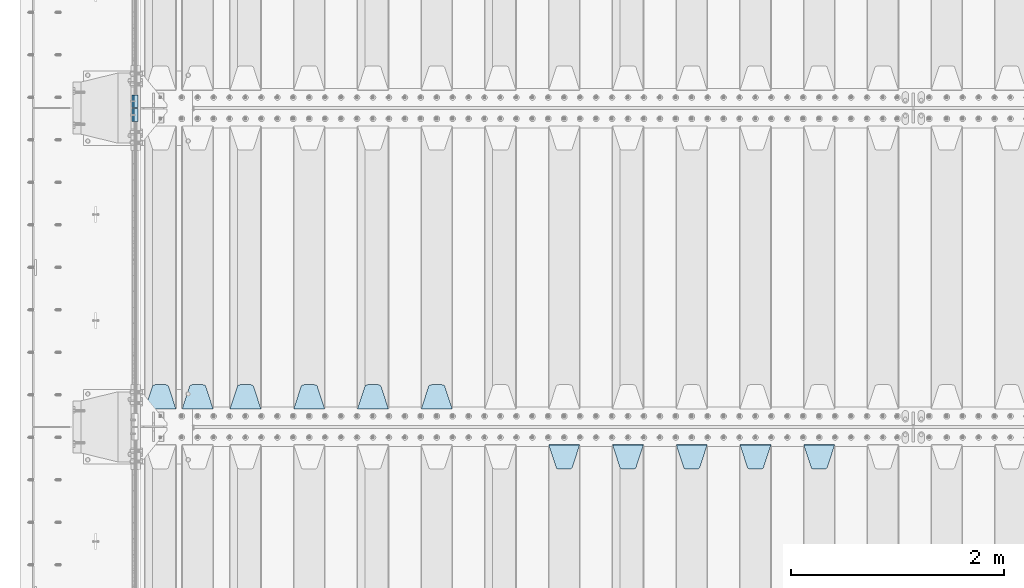
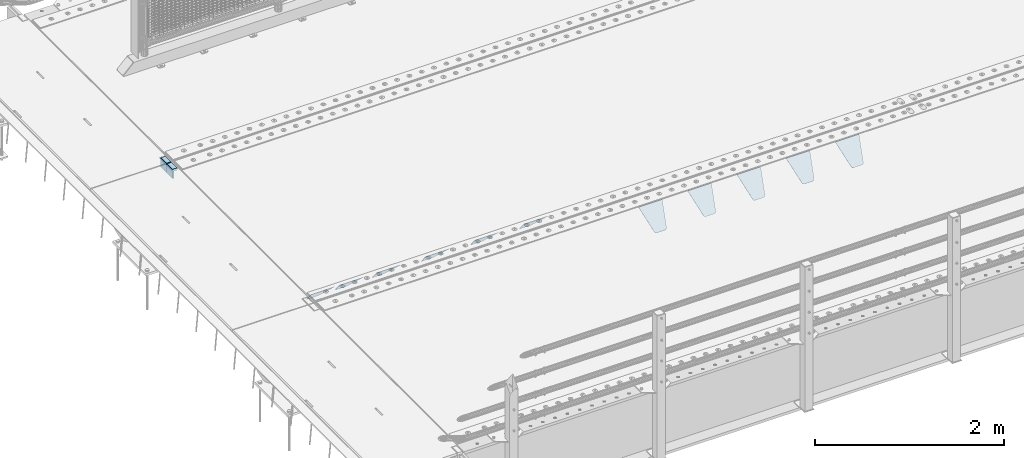
# One storey, part 217 of 270: 15 plates.
"""IFC2X3 building model written with IfcOpenShell, lengths in millimetres."""

from ifc_helpers import new_model, si_unit, frame, origin_with_axes, place, context, subcontext, project, spatial, faceted_brep, material, type_object, element, save


model = new_model("IFC2X3")

# Units and contexts
model_context = context("Model", 3, precision=1e-05, world=origin_with_axes())
body_context = subcontext(model_context, "Body", "Model", "MODEL_VIEW")
ifc_project = project(units=[si_unit("LENGTHUNIT", "METRE", prefix="MILLI"), si_unit("AREAUNIT", "SQUARE_METRE"), si_unit("VOLUMEUNIT", "CUBIC_METRE"), si_unit("MASSUNIT", "GRAM", prefix="KILO"), si_unit("TIMEUNIT", "SECOND"), si_unit("PLANEANGLEUNIT", "RADIAN"), si_unit("SOLIDANGLEUNIT", "STERADIAN"), si_unit("THERMODYNAMICTEMPERATUREUNIT", "DEGREE_CELSIUS"), si_unit("LUMINOUSINTENSITYUNIT", "LUMEN")], contexts=[model_context])

# Site, building, storey
site_placement = place(None, origin_with_axes())
site = spatial("IfcSite", under=ifc_project, at=site_placement, CompositionType="ELEMENT")
building_placement = place(site_placement, origin_with_axes())
building = spatial("IfcBuilding", under=site, at=building_placement, Name="Standard", CompositionType="ELEMENT")
storey_placement = place(building_placement, origin_with_axes())
storey = spatial("IfcBuildingStorey", under=building, at=storey_placement, Name="Undefined", CompositionType="ELEMENT", Elevation=0.0)

# Plates
ifc_material_1 = material()
plate_type_1 = type_object("IfcPlateType", PredefinedType="NOTDEFINED")
for number, where, z_axis, x_axis in (
    (1, (-9.99999993997335, -18064.9999995664, -16.000386849525), (-1.0, 0.0, 0.0), (0.0, -4.95099997756316e-06, 0.999999999987744)),
    (2, (-10.0000000600267, -17934.9999995681, -15.9997432191214), (-1.0, 0.0, 0.0), (0.0, -4.95099997756316e-06, 0.999999999987744)),
):
    element("IfcPlate", number, at=place(storey_placement, frame(where, z_axis=z_axis, x_axis=x_axis)), inside=storey, type_object=plate_type_1, material=ifc_material_1, context=body_context, shape_type="Brep", body=[
        faceted_brep([(1.77635683940025e-15, -60.0000000000073, 0.0), (-0.000933120085688799, -60.0000000000036, 60.0), (-0.000933120085688799, 59.9999999999964, 60.0), (-1.77635683940025e-15, 59.9999999999964, 0.0), (24.9991450303709, -60.0, 60.0), (24.9991450303709, 59.9999999999964, 60.0), (26.544215218168, -60.0000000000036, 59.7552873850884), (26.544215218168, 60.0, 59.7552873850884), (27.9380461396139, -60.0000000000036, 59.0451032459123), (27.9380461396139, 60.0, 59.0451032459123), (29.0442025908961, -60.0000000000036, 57.9389639895784), (29.0442025908961, 60.0, 57.9389639895784), (29.7544083969366, -60.0, 56.5451441080361), (29.7544083969366, 60.0000000000036, 56.5451441080361), (29.9991450297669, -60.0000000000036, 55.0000777244568), (29.9991450297669, 60.0, 55.0000777244568), (29.999922274335, -60.0, 5.00007772445705), (29.999922274335, 60.0, 5.00007772445704), (29.7552240705896, -60.0000000000036, 3.45497416452589), (29.7552240705896, 60.0, 3.45497416452589), (29.0450346578116, -60.0, 2.06111146690959), (29.0450346578116, 59.9999999999964, 2.0611114669096), (27.9388736885072, -60.0, 0.954933302319514), (27.9388736885072, 59.9999999999964, 0.954933302319516), (26.5450220308766, -60.0000000000036, 0.244722222183089), (26.5450220308766, 60.0, 0.244722222183091), (24.9999222749392, -60.0, 2.66453525910038e-13), (24.9999222749392, 60.0, 2.66453525910038e-13)], [[[0, 1, 2, 3]], [[1, 4, 5, 2]], [[4, 6, 7, 5]], [[6, 8, 9, 7]], [[8, 10, 11, 9]], [[10, 12, 13, 11]], [[12, 14, 15, 13]], [[14, 16, 17, 15]], [[16, 18, 19, 17]], [[18, 20, 21, 19]], [[20, 22, 23, 21]], [[22, 24, 25, 23]], [[24, 26, 27, 25]], [[26, 0, 3, 27]], [[5, 7, 9, 11, 13, 15, 17, 19, 21, 23, 25, 27, 3, 2]], [[26, 24, 22, 20, 18, 16, 14, 12, 10, 8, 6, 4, 1, 0]]]),
    ])
ifc_material_2 = material(Name="STEEL/S355N")
plate_type_2 = type_object("IfcPlateType", PredefinedType="NOTDEFINED")
for number, where, z_axis, x_axis in (
    (3, (-60.0, -18004.9995540169, -106.000711879208), (0.0, -0.999999999987744, -4.95099999993769e-06), (0.0, -4.95099997756316e-06, 0.999999999987744)),
    (4, (-60.0, -17874.9995540187, -106.000068249326), (0.0, -0.999999999987744, -4.95099999993769e-06), (0.0, -4.95099997756316e-06, 0.999999999987744)),
):
    element("IfcPlate", number, at=place(storey_placement, frame(where, z_axis=z_axis, x_axis=x_axis)), inside=storey, type_object=plate_type_2, material=ifc_material_2, context=body_context, shape_type="Brep", body=[
        faceted_brep([(0.0, -10.0, 0.0), (4.30830482400779e-10, -10.0, 120.000000000004), (4.30830482400779e-10, 10.0, 120.000000000004), (0.0, 10.0, 0.0), (89.9999999999979, -10.0, 120.000000000004), (89.9999999999979, 10.0, 120.000000000004), (90.0, -10.0, 1.09139364212751e-11), (90.0, 10.0, 1.09139364212751e-11)], [[[0, 1, 2, 3]], [[1, 4, 5, 2]], [[4, 6, 7, 5]], [[6, 0, 3, 7]], [[5, 7, 3, 2]], [[6, 4, 1, 0]]]),
    ])
plate_type_3 = type_object("IfcPlateType", PredefinedType="NOTDEFINED")
plate_1_placement = place(storey_placement, frame((2945.0, -20831.767766953, -1.76776695296758), z_axis=(0.0, 0.707106781186547, -0.707106781186548), x_axis=(-1.0, 0.0, 0.0)))
element("IfcPlate", 5, at=plate_1_placement, inside=storey, type_object=plate_type_3, material=ifc_material_2, context=body_context, shape_type="Brep", body=[
    faceted_brep([(0.0, -2.5, 0.0), (69.345504679477, -2.5, 300.171731424831), (69.345504679477, 2.5, 300.171731424831), (0.0, 2.5, 0.0), (70.9274061199576, -2.5, 304.8974424154), (70.9274061199576, 2.5, 304.8974424154), (73.3818627772307, -2.49999999999818, 309.234538108527), (73.3818627772307, 2.50000000000182, 309.234538108527), (76.6187032999551, -2.5, 313.023683126103), (76.6187032999551, 2.5, 313.023683126103), (80.5190132704993, -2.5, 316.125672595372), (80.5190132704993, 2.50000000000182, 316.125672595372), (84.9395038596849, -2.49999999999818, 318.426546230476), (84.9395038596849, 2.5, 318.426546230476), (89.7177759439219, -2.49999999999818, 319.841774983275), (89.7177759439219, 2.50000000000182, 319.841774983275), (94.678286292652, -2.5, 320.319366455078), (94.678286292652, 2.5, 320.319366455078), (195.321713707348, -2.5, 320.319366455078), (195.321713707348, 2.5, 320.319366455078), (200.282224056078, -2.49999999999818, 319.841774983275), (200.282224056078, 2.50000000000182, 319.841774983275), (205.060496140315, -2.5, 318.426546230476), (205.060496140315, 2.5, 318.426546230476), (209.480986729501, -2.5, 316.12567259537), (209.480986729501, 2.50000000000182, 316.12567259537), (213.381296700045, -2.5, 313.023683126103), (213.381296700045, 2.5, 313.023683126103), (216.618137222769, -2.49999999999818, 309.234538108525), (216.618137222769, 2.50000000000182, 309.234538108527), (219.072593880042, -2.49999999999818, 304.897442415398), (219.072593880042, 2.50000000000182, 304.897442415397), (220.654495320523, -2.5, 300.171731424831), (220.654495320523, 2.5, 300.171731424831), (290.0, -2.49999999999818, 0.0), (290.0, 2.5, 0.0)], [[[0, 1, 2, 3]], [[1, 4, 5, 2]], [[4, 6, 7, 5]], [[6, 8, 9, 7]], [[8, 10, 11, 9]], [[10, 12, 13, 11]], [[12, 14, 15, 13]], [[14, 16, 17, 15]], [[16, 18, 19, 17]], [[18, 20, 21, 19]], [[20, 22, 23, 21]], [[22, 24, 25, 23]], [[24, 26, 27, 25]], [[26, 28, 29, 27]], [[28, 30, 31, 29]], [[30, 32, 33, 31]], [[32, 34, 35, 33]], [[34, 0, 3, 35]], [[5, 7, 9, 11, 13, 15, 17, 19, 21, 23, 25, 27, 29, 31, 33, 35, 3, 2]], [[34, 32, 30, 28, 26, 24, 22, 20, 18, 16, 14, 12, 10, 8, 6, 4, 1, 0]]]),
])
plate_2_placement = place(storey_placement, frame((2345.0, -20831.767766953, -1.76776695296758), z_axis=(0.0, 0.707106781186547, -0.707106781186548), x_axis=(-1.0, 0.0, 0.0)))
element("IfcPlate", 6, at=plate_2_placement, inside=storey, type_object=plate_type_3, material=ifc_material_2, context=body_context, shape_type="Brep", body=[
    faceted_brep([(0.0, -2.5, 0.0), (69.345504679477, -2.5, 300.171731424831), (69.345504679477, 2.5, 300.171731424831), (0.0, 2.5, 0.0), (70.9274061199576, -2.5, 304.8974424154), (70.9274061199576, 2.5, 304.8974424154), (73.3818627772307, -2.49999999999818, 309.234538108527), (73.3818627772307, 2.50000000000182, 309.234538108527), (76.6187032999551, -2.5, 313.023683126103), (76.6187032999551, 2.5, 313.023683126103), (80.5190132704993, -2.5, 316.125672595372), (80.5190132704993, 2.50000000000182, 316.125672595372), (84.9395038596849, -2.49999999999818, 318.426546230476), (84.9395038596849, 2.5, 318.426546230476), (89.7177759439219, -2.49999999999818, 319.841774983275), (89.7177759439219, 2.50000000000182, 319.841774983275), (94.678286292652, -2.5, 320.319366455078), (94.678286292652, 2.5, 320.319366455078), (195.321713707348, -2.5, 320.319366455078), (195.321713707348, 2.5, 320.319366455078), (200.282224056078, -2.49999999999818, 319.841774983275), (200.282224056078, 2.50000000000182, 319.841774983275), (205.060496140315, -2.5, 318.426546230476), (205.060496140315, 2.5, 318.426546230476), (209.480986729501, -2.5, 316.12567259537), (209.480986729501, 2.50000000000182, 316.12567259537), (213.381296700045, -2.5, 313.023683126103), (213.381296700045, 2.5, 313.023683126103), (216.618137222769, -2.49999999999818, 309.234538108525), (216.618137222769, 2.50000000000182, 309.234538108527), (219.072593880042, -2.49999999999818, 304.897442415398), (219.072593880042, 2.50000000000182, 304.897442415397), (220.654495320523, -2.5, 300.171731424831), (220.654495320523, 2.5, 300.171731424831), (290.0, -2.49999999999818, 0.0), (290.0, 2.5, 0.0)], [[[0, 1, 2, 3]], [[1, 4, 5, 2]], [[4, 6, 7, 5]], [[6, 8, 9, 7]], [[8, 10, 11, 9]], [[10, 12, 13, 11]], [[12, 14, 15, 13]], [[14, 16, 17, 15]], [[16, 18, 19, 17]], [[18, 20, 21, 19]], [[20, 22, 23, 21]], [[22, 24, 25, 23]], [[24, 26, 27, 25]], [[26, 28, 29, 27]], [[28, 30, 31, 29]], [[30, 32, 33, 31]], [[32, 34, 35, 33]], [[34, 0, 3, 35]], [[5, 7, 9, 11, 13, 15, 17, 19, 21, 23, 25, 27, 29, 31, 33, 35, 3, 2]], [[34, 32, 30, 28, 26, 24, 22, 20, 18, 16, 14, 12, 10, 8, 6, 4, 1, 0]]]),
])
plate_3_placement = place(storey_placement, frame((1745.0, -20831.767766953, -1.76776695296758), z_axis=(0.0, 0.707106781186547, -0.707106781186548), x_axis=(-1.0, 0.0, 0.0)))
element("IfcPlate", 7, at=plate_3_placement, inside=storey, type_object=plate_type_3, material=ifc_material_2, context=body_context, shape_type="Brep", body=[
    faceted_brep([(0.0, -2.5, 0.0), (69.345504679477, -2.5, 300.171731424831), (69.345504679477, 2.5, 300.171731424831), (0.0, 2.5, 0.0), (70.9274061199576, -2.5, 304.8974424154), (70.9274061199576, 2.5, 304.8974424154), (73.3818627772307, -2.49999999999818, 309.234538108527), (73.3818627772307, 2.50000000000182, 309.234538108527), (76.6187032999551, -2.5, 313.023683126103), (76.6187032999551, 2.5, 313.023683126103), (80.5190132704993, -2.5, 316.125672595372), (80.5190132704993, 2.50000000000182, 316.125672595372), (84.9395038596849, -2.49999999999818, 318.426546230476), (84.9395038596849, 2.5, 318.426546230476), (89.7177759439219, -2.49999999999818, 319.841774983275), (89.7177759439219, 2.50000000000182, 319.841774983275), (94.678286292652, -2.5, 320.319366455078), (94.678286292652, 2.5, 320.319366455078), (195.321713707348, -2.5, 320.319366455078), (195.321713707348, 2.5, 320.319366455078), (200.282224056078, -2.49999999999818, 319.841774983275), (200.282224056078, 2.50000000000182, 319.841774983275), (205.060496140315, -2.5, 318.426546230476), (205.060496140315, 2.5, 318.426546230476), (209.480986729501, -2.5, 316.12567259537), (209.480986729501, 2.50000000000182, 316.12567259537), (213.381296700045, -2.5, 313.023683126103), (213.381296700045, 2.5, 313.023683126103), (216.618137222769, -2.49999999999818, 309.234538108525), (216.618137222769, 2.50000000000182, 309.234538108527), (219.072593880042, -2.49999999999818, 304.897442415398), (219.072593880042, 2.50000000000182, 304.897442415397), (220.654495320523, -2.5, 300.171731424831), (220.654495320523, 2.5, 300.171731424831), (290.0, -2.49999999999818, 0.0), (290.0, 2.5, 0.0)], [[[0, 1, 2, 3]], [[1, 4, 5, 2]], [[4, 6, 7, 5]], [[6, 8, 9, 7]], [[8, 10, 11, 9]], [[10, 12, 13, 11]], [[12, 14, 15, 13]], [[14, 16, 17, 15]], [[16, 18, 19, 17]], [[18, 20, 21, 19]], [[20, 22, 23, 21]], [[22, 24, 25, 23]], [[24, 26, 27, 25]], [[26, 28, 29, 27]], [[28, 30, 31, 29]], [[30, 32, 33, 31]], [[32, 34, 35, 33]], [[34, 0, 3, 35]], [[5, 7, 9, 11, 13, 15, 17, 19, 21, 23, 25, 27, 29, 31, 33, 35, 3, 2]], [[34, 32, 30, 28, 26, 24, 22, 20, 18, 16, 14, 12, 10, 8, 6, 4, 1, 0]]]),
])
plate_4_placement = place(storey_placement, frame((1145.0, -20831.767766953, -1.76776695296758), z_axis=(0.0, 0.707106781186547, -0.707106781186548), x_axis=(-1.0, 0.0, 0.0)))
element("IfcPlate", 8, at=plate_4_placement, inside=storey, type_object=plate_type_3, material=ifc_material_2, context=body_context, shape_type="Brep", body=[
    faceted_brep([(0.0, -2.5, 0.0), (69.345504679477, -2.5, 300.171731424831), (69.345504679477, 2.5, 300.171731424831), (0.0, 2.5, 0.0), (70.9274061199576, -2.5, 304.8974424154), (70.9274061199576, 2.5, 304.8974424154), (73.3818627772307, -2.49999999999818, 309.234538108527), (73.3818627772307, 2.50000000000182, 309.234538108527), (76.6187032999551, -2.5, 313.023683126103), (76.6187032999551, 2.5, 313.023683126103), (80.5190132704993, -2.5, 316.125672595372), (80.5190132704993, 2.50000000000182, 316.125672595372), (84.9395038596849, -2.49999999999818, 318.426546230476), (84.9395038596849, 2.5, 318.426546230476), (89.7177759439219, -2.49999999999818, 319.841774983275), (89.7177759439219, 2.50000000000182, 319.841774983275), (94.678286292652, -2.5, 320.319366455078), (94.678286292652, 2.5, 320.319366455078), (195.321713707348, -2.5, 320.319366455078), (195.321713707348, 2.5, 320.319366455078), (200.282224056078, -2.49999999999818, 319.841774983275), (200.282224056078, 2.50000000000182, 319.841774983275), (205.060496140315, -2.5, 318.426546230476), (205.060496140315, 2.5, 318.426546230476), (209.480986729501, -2.5, 316.12567259537), (209.480986729501, 2.50000000000182, 316.12567259537), (213.381296700045, -2.5, 313.023683126103), (213.381296700045, 2.5, 313.023683126103), (216.618137222769, -2.49999999999818, 309.234538108525), (216.618137222769, 2.50000000000182, 309.234538108527), (219.072593880042, -2.49999999999818, 304.897442415398), (219.072593880042, 2.50000000000182, 304.897442415397), (220.654495320523, -2.5, 300.171731424831), (220.654495320523, 2.5, 300.171731424831), (290.0, -2.49999999999818, 0.0), (290.0, 2.5, 0.0)], [[[0, 1, 2, 3]], [[1, 4, 5, 2]], [[4, 6, 7, 5]], [[6, 8, 9, 7]], [[8, 10, 11, 9]], [[10, 12, 13, 11]], [[12, 14, 15, 13]], [[14, 16, 17, 15]], [[16, 18, 19, 17]], [[18, 20, 21, 19]], [[20, 22, 23, 21]], [[22, 24, 25, 23]], [[24, 26, 27, 25]], [[26, 28, 29, 27]], [[28, 30, 31, 29]], [[30, 32, 33, 31]], [[32, 34, 35, 33]], [[34, 0, 3, 35]], [[5, 7, 9, 11, 13, 15, 17, 19, 21, 23, 25, 27, 29, 31, 33, 35, 3, 2]], [[34, 32, 30, 28, 26, 24, 22, 20, 18, 16, 14, 12, 10, 8, 6, 4, 1, 0]]]),
])
plate_5_placement = place(storey_placement, frame((695.0, -20831.767766953, -1.76776695296758), z_axis=(0.0, 0.707106781186547, -0.707106781186548), x_axis=(-1.0, 0.0, 0.0)))
element("IfcPlate", 9, at=plate_5_placement, inside=storey, type_object=plate_type_3, material=ifc_material_2, context=body_context, shape_type="Brep", body=[
    faceted_brep([(0.0, -2.5, 0.0), (69.345504679477, -2.5, 300.171731424831), (69.345504679477, 2.5, 300.171731424831), (0.0, 2.5, 0.0), (70.9274061199576, -2.5, 304.8974424154), (70.9274061199576, 2.5, 304.8974424154), (73.3818627772307, -2.49999999999818, 309.234538108527), (73.3818627772307, 2.50000000000182, 309.234538108527), (76.6187032999551, -2.5, 313.023683126103), (76.6187032999551, 2.5, 313.023683126103), (80.5190132704993, -2.5, 316.125672595372), (80.5190132704993, 2.50000000000182, 316.125672595372), (84.9395038596849, -2.49999999999818, 318.426546230476), (84.9395038596849, 2.5, 318.426546230476), (89.7177759439219, -2.49999999999818, 319.841774983275), (89.7177759439219, 2.50000000000182, 319.841774983275), (94.678286292652, -2.5, 320.319366455078), (94.678286292652, 2.5, 320.319366455078), (195.321713707348, -2.5, 320.319366455078), (195.321713707348, 2.5, 320.319366455078), (200.282224056078, -2.49999999999818, 319.841774983275), (200.282224056078, 2.50000000000182, 319.841774983275), (205.060496140315, -2.5, 318.426546230476), (205.060496140315, 2.5, 318.426546230476), (209.480986729501, -2.5, 316.12567259537), (209.480986729501, 2.50000000000182, 316.12567259537), (213.381296700045, -2.5, 313.023683126103), (213.381296700045, 2.5, 313.023683126103), (216.618137222769, -2.49999999999818, 309.234538108525), (216.618137222769, 2.50000000000182, 309.234538108527), (219.072593880042, -2.49999999999818, 304.897442415398), (219.072593880042, 2.50000000000182, 304.897442415397), (220.654495320523, -2.5, 300.171731424831), (220.654495320523, 2.5, 300.171731424831), (290.0, -2.49999999999818, 0.0), (290.0, 2.5, 0.0)], [[[0, 1, 2, 3]], [[1, 4, 5, 2]], [[4, 6, 7, 5]], [[6, 8, 9, 7]], [[8, 10, 11, 9]], [[10, 12, 13, 11]], [[12, 14, 15, 13]], [[14, 16, 17, 15]], [[16, 18, 19, 17]], [[18, 20, 21, 19]], [[20, 22, 23, 21]], [[22, 24, 25, 23]], [[24, 26, 27, 25]], [[26, 28, 29, 27]], [[28, 30, 31, 29]], [[30, 32, 33, 31]], [[32, 34, 35, 33]], [[34, 0, 3, 35]], [[5, 7, 9, 11, 13, 15, 17, 19, 21, 23, 25, 27, 29, 31, 33, 35, 3, 2]], [[34, 32, 30, 28, 26, 24, 22, 20, 18, 16, 14, 12, 10, 8, 6, 4, 1, 0]]]),
])
plate_6_placement = place(storey_placement, frame((6255.0, -21168.232233044, -1.76776695296576), z_axis=(0.0, -0.707106781186548, -0.707106781186547), x_axis=(1.0, 0.0, 0.0)))
element("IfcPlate", 10, at=plate_6_placement, inside=storey, type_object=plate_type_3, material=ifc_material_2, context=body_context, shape_type="Brep", body=[
    faceted_brep([(0.0, -2.5, 0.0), (69.345504679477, -2.5, 300.171731424831), (69.345504679477, 2.5, 300.171731424831), (0.0, 2.5, 0.0), (70.9274061199576, -2.5, 304.8974424154), (70.9274061199576, 2.5, 304.8974424154), (73.3818627772307, -2.49999999999818, 309.234538108527), (73.3818627772307, 2.50000000000182, 309.234538108527), (76.6187032999551, -2.5, 313.023683126103), (76.6187032999551, 2.5, 313.023683126103), (80.5190132704993, -2.5, 316.125672595372), (80.5190132704993, 2.50000000000182, 316.125672595372), (84.9395038596849, -2.49999999999818, 318.426546230476), (84.9395038596849, 2.5, 318.426546230476), (89.7177759439219, -2.49999999999818, 319.841774983275), (89.7177759439219, 2.50000000000182, 319.841774983275), (94.678286292652, -2.5, 320.319366455078), (94.678286292652, 2.5, 320.319366455078), (195.321713707348, -2.5, 320.319366455078), (195.321713707348, 2.5, 320.319366455078), (200.282224056078, -2.49999999999818, 319.841774983275), (200.282224056078, 2.50000000000182, 319.841774983275), (205.060496140315, -2.5, 318.426546230476), (205.060496140315, 2.5, 318.426546230476), (209.480986729501, -2.5, 316.12567259537), (209.480986729501, 2.50000000000182, 316.12567259537), (213.381296700045, -2.5, 313.023683126103), (213.381296700045, 2.5, 313.023683126103), (216.618137222769, -2.49999999999818, 309.234538108525), (216.618137222769, 2.50000000000182, 309.234538108527), (219.072593880042, -2.49999999999818, 304.897442415398), (219.072593880042, 2.50000000000182, 304.897442415397), (220.654495320523, -2.5, 300.171731424831), (220.654495320523, 2.5, 300.171731424831), (290.0, -2.49999999999818, 0.0), (290.0, 2.5, 0.0)], [[[0, 1, 2, 3]], [[1, 4, 5, 2]], [[4, 6, 7, 5]], [[6, 8, 9, 7]], [[8, 10, 11, 9]], [[10, 12, 13, 11]], [[12, 14, 15, 13]], [[14, 16, 17, 15]], [[16, 18, 19, 17]], [[18, 20, 21, 19]], [[20, 22, 23, 21]], [[22, 24, 25, 23]], [[24, 26, 27, 25]], [[26, 28, 29, 27]], [[28, 30, 31, 29]], [[30, 32, 33, 31]], [[32, 34, 35, 33]], [[34, 0, 3, 35]], [[5, 7, 9, 11, 13, 15, 17, 19, 21, 23, 25, 27, 29, 31, 33, 35, 3, 2]], [[34, 32, 30, 28, 26, 24, 22, 20, 18, 16, 14, 12, 10, 8, 6, 4, 1, 0]]]),
])
plate_7_placement = place(storey_placement, frame((5655.0, -21168.232233044, -1.76776695296576), z_axis=(0.0, -0.707106781186548, -0.707106781186547), x_axis=(1.0, 0.0, 0.0)))
element("IfcPlate", 11, at=plate_7_placement, inside=storey, type_object=plate_type_3, material=ifc_material_2, context=body_context, shape_type="Brep", body=[
    faceted_brep([(0.0, -2.5, 0.0), (69.345504679477, -2.5, 300.171731424831), (69.345504679477, 2.5, 300.171731424831), (0.0, 2.5, 0.0), (70.9274061199576, -2.5, 304.8974424154), (70.9274061199576, 2.5, 304.8974424154), (73.3818627772307, -2.49999999999818, 309.234538108527), (73.3818627772307, 2.50000000000182, 309.234538108527), (76.6187032999551, -2.5, 313.023683126103), (76.6187032999551, 2.5, 313.023683126103), (80.5190132704993, -2.5, 316.125672595372), (80.5190132704993, 2.50000000000182, 316.125672595372), (84.9395038596849, -2.49999999999818, 318.426546230476), (84.9395038596849, 2.5, 318.426546230476), (89.7177759439219, -2.49999999999818, 319.841774983275), (89.7177759439219, 2.50000000000182, 319.841774983275), (94.678286292652, -2.5, 320.319366455078), (94.678286292652, 2.5, 320.319366455078), (195.321713707348, -2.5, 320.319366455078), (195.321713707348, 2.5, 320.319366455078), (200.282224056078, -2.49999999999818, 319.841774983275), (200.282224056078, 2.50000000000182, 319.841774983275), (205.060496140315, -2.5, 318.426546230476), (205.060496140315, 2.5, 318.426546230476), (209.480986729501, -2.5, 316.12567259537), (209.480986729501, 2.50000000000182, 316.12567259537), (213.381296700045, -2.5, 313.023683126103), (213.381296700045, 2.5, 313.023683126103), (216.618137222769, -2.49999999999818, 309.234538108525), (216.618137222769, 2.50000000000182, 309.234538108527), (219.072593880042, -2.49999999999818, 304.897442415398), (219.072593880042, 2.50000000000182, 304.897442415397), (220.654495320523, -2.5, 300.171731424831), (220.654495320523, 2.5, 300.171731424831), (290.0, -2.49999999999818, 0.0), (290.0, 2.5, 0.0)], [[[0, 1, 2, 3]], [[1, 4, 5, 2]], [[4, 6, 7, 5]], [[6, 8, 9, 7]], [[8, 10, 11, 9]], [[10, 12, 13, 11]], [[12, 14, 15, 13]], [[14, 16, 17, 15]], [[16, 18, 19, 17]], [[18, 20, 21, 19]], [[20, 22, 23, 21]], [[22, 24, 25, 23]], [[24, 26, 27, 25]], [[26, 28, 29, 27]], [[28, 30, 31, 29]], [[30, 32, 33, 31]], [[32, 34, 35, 33]], [[34, 0, 3, 35]], [[5, 7, 9, 11, 13, 15, 17, 19, 21, 23, 25, 27, 29, 31, 33, 35, 3, 2]], [[34, 32, 30, 28, 26, 24, 22, 20, 18, 16, 14, 12, 10, 8, 6, 4, 1, 0]]]),
])
plate_8_placement = place(storey_placement, frame((5055.0, -21168.232233044, -1.76776695296576), z_axis=(0.0, -0.707106781186548, -0.707106781186547), x_axis=(1.0, 0.0, 0.0)))
element("IfcPlate", 12, at=plate_8_placement, inside=storey, type_object=plate_type_3, material=ifc_material_2, context=body_context, shape_type="Brep", body=[
    faceted_brep([(0.0, -2.5, 0.0), (69.345504679477, -2.5, 300.171731424831), (69.345504679477, 2.5, 300.171731424831), (0.0, 2.5, 0.0), (70.9274061199576, -2.5, 304.8974424154), (70.9274061199576, 2.5, 304.8974424154), (73.3818627772307, -2.49999999999818, 309.234538108527), (73.3818627772307, 2.50000000000182, 309.234538108527), (76.6187032999551, -2.5, 313.023683126103), (76.6187032999551, 2.5, 313.023683126103), (80.5190132704993, -2.5, 316.125672595372), (80.5190132704993, 2.50000000000182, 316.125672595372), (84.9395038596849, -2.49999999999818, 318.426546230476), (84.9395038596849, 2.5, 318.426546230476), (89.7177759439219, -2.49999999999818, 319.841774983275), (89.7177759439219, 2.50000000000182, 319.841774983275), (94.678286292652, -2.5, 320.319366455078), (94.678286292652, 2.5, 320.319366455078), (195.321713707348, -2.5, 320.319366455078), (195.321713707348, 2.5, 320.319366455078), (200.282224056078, -2.49999999999818, 319.841774983275), (200.282224056078, 2.50000000000182, 319.841774983275), (205.060496140315, -2.5, 318.426546230476), (205.060496140315, 2.5, 318.426546230476), (209.480986729501, -2.5, 316.12567259537), (209.480986729501, 2.50000000000182, 316.12567259537), (213.381296700045, -2.5, 313.023683126103), (213.381296700045, 2.5, 313.023683126103), (216.618137222769, -2.49999999999818, 309.234538108525), (216.618137222769, 2.50000000000182, 309.234538108527), (219.072593880042, -2.49999999999818, 304.897442415398), (219.072593880042, 2.50000000000182, 304.897442415397), (220.654495320523, -2.5, 300.171731424831), (220.654495320523, 2.5, 300.171731424831), (290.0, -2.49999999999818, 0.0), (290.0, 2.5, 0.0)], [[[0, 1, 2, 3]], [[1, 4, 5, 2]], [[4, 6, 7, 5]], [[6, 8, 9, 7]], [[8, 10, 11, 9]], [[10, 12, 13, 11]], [[12, 14, 15, 13]], [[14, 16, 17, 15]], [[16, 18, 19, 17]], [[18, 20, 21, 19]], [[20, 22, 23, 21]], [[22, 24, 25, 23]], [[24, 26, 27, 25]], [[26, 28, 29, 27]], [[28, 30, 31, 29]], [[30, 32, 33, 31]], [[32, 34, 35, 33]], [[34, 0, 3, 35]], [[5, 7, 9, 11, 13, 15, 17, 19, 21, 23, 25, 27, 29, 31, 33, 35, 3, 2]], [[34, 32, 30, 28, 26, 24, 22, 20, 18, 16, 14, 12, 10, 8, 6, 4, 1, 0]]]),
])
plate_9_placement = place(storey_placement, frame((4455.0, -21168.232233044, -1.76776695296576), z_axis=(0.0, -0.707106781186548, -0.707106781186547), x_axis=(1.0, 0.0, 0.0)))
element("IfcPlate", 13, at=plate_9_placement, inside=storey, type_object=plate_type_3, material=ifc_material_2, context=body_context, shape_type="Brep", body=[
    faceted_brep([(0.0, -2.5, 0.0), (69.345504679477, -2.5, 300.171731424831), (69.345504679477, 2.5, 300.171731424831), (0.0, 2.5, 0.0), (70.9274061199576, -2.5, 304.8974424154), (70.9274061199576, 2.5, 304.8974424154), (73.3818627772307, -2.49999999999818, 309.234538108527), (73.3818627772307, 2.50000000000182, 309.234538108527), (76.6187032999551, -2.5, 313.023683126103), (76.6187032999551, 2.5, 313.023683126103), (80.5190132704993, -2.5, 316.125672595372), (80.5190132704993, 2.50000000000182, 316.125672595372), (84.9395038596849, -2.49999999999818, 318.426546230476), (84.9395038596849, 2.5, 318.426546230476), (89.7177759439219, -2.49999999999818, 319.841774983275), (89.7177759439219, 2.50000000000182, 319.841774983275), (94.678286292652, -2.5, 320.319366455078), (94.678286292652, 2.5, 320.319366455078), (195.321713707348, -2.5, 320.319366455078), (195.321713707348, 2.5, 320.319366455078), (200.282224056078, -2.49999999999818, 319.841774983275), (200.282224056078, 2.50000000000182, 319.841774983275), (205.060496140315, -2.5, 318.426546230476), (205.060496140315, 2.5, 318.426546230476), (209.480986729501, -2.5, 316.12567259537), (209.480986729501, 2.50000000000182, 316.12567259537), (213.381296700045, -2.5, 313.023683126103), (213.381296700045, 2.5, 313.023683126103), (216.618137222769, -2.49999999999818, 309.234538108525), (216.618137222769, 2.50000000000182, 309.234538108527), (219.072593880042, -2.49999999999818, 304.897442415398), (219.072593880042, 2.50000000000182, 304.897442415397), (220.654495320523, -2.5, 300.171731424831), (220.654495320523, 2.5, 300.171731424831), (290.0, -2.49999999999818, 0.0), (290.0, 2.5, 0.0)], [[[0, 1, 2, 3]], [[1, 4, 5, 2]], [[4, 6, 7, 5]], [[6, 8, 9, 7]], [[8, 10, 11, 9]], [[10, 12, 13, 11]], [[12, 14, 15, 13]], [[14, 16, 17, 15]], [[16, 18, 19, 17]], [[18, 20, 21, 19]], [[20, 22, 23, 21]], [[22, 24, 25, 23]], [[24, 26, 27, 25]], [[26, 28, 29, 27]], [[28, 30, 31, 29]], [[30, 32, 33, 31]], [[32, 34, 35, 33]], [[34, 0, 3, 35]], [[5, 7, 9, 11, 13, 15, 17, 19, 21, 23, 25, 27, 29, 31, 33, 35, 3, 2]], [[34, 32, 30, 28, 26, 24, 22, 20, 18, 16, 14, 12, 10, 8, 6, 4, 1, 0]]]),
])
plate_10_placement = place(storey_placement, frame((3855.0, -21168.232233044, -1.76776695296576), z_axis=(0.0, -0.707106781186548, -0.707106781186547), x_axis=(1.0, 0.0, 0.0)))
element("IfcPlate", 14, at=plate_10_placement, inside=storey, type_object=plate_type_3, material=ifc_material_2, context=body_context, shape_type="Brep", body=[
    faceted_brep([(0.0, -2.5, 0.0), (69.345504679477, -2.5, 300.171731424831), (69.345504679477, 2.5, 300.171731424831), (0.0, 2.5, 0.0), (70.9274061199576, -2.5, 304.8974424154), (70.9274061199576, 2.5, 304.8974424154), (73.3818627772307, -2.49999999999818, 309.234538108527), (73.3818627772307, 2.50000000000182, 309.234538108527), (76.6187032999551, -2.5, 313.023683126103), (76.6187032999551, 2.5, 313.023683126103), (80.5190132704993, -2.5, 316.125672595372), (80.5190132704993, 2.50000000000182, 316.125672595372), (84.9395038596849, -2.49999999999818, 318.426546230476), (84.9395038596849, 2.5, 318.426546230476), (89.7177759439219, -2.49999999999818, 319.841774983275), (89.7177759439219, 2.50000000000182, 319.841774983275), (94.678286292652, -2.5, 320.319366455078), (94.678286292652, 2.5, 320.319366455078), (195.321713707348, -2.5, 320.319366455078), (195.321713707348, 2.5, 320.319366455078), (200.282224056078, -2.49999999999818, 319.841774983275), (200.282224056078, 2.50000000000182, 319.841774983275), (205.060496140315, -2.5, 318.426546230476), (205.060496140315, 2.5, 318.426546230476), (209.480986729501, -2.5, 316.12567259537), (209.480986729501, 2.50000000000182, 316.12567259537), (213.381296700045, -2.5, 313.023683126103), (213.381296700045, 2.5, 313.023683126103), (216.618137222769, -2.49999999999818, 309.234538108525), (216.618137222769, 2.50000000000182, 309.234538108527), (219.072593880042, -2.49999999999818, 304.897442415398), (219.072593880042, 2.50000000000182, 304.897442415397), (220.654495320523, -2.5, 300.171731424831), (220.654495320523, 2.5, 300.171731424831), (290.0, -2.49999999999818, 0.0), (290.0, 2.5, 0.0)], [[[0, 1, 2, 3]], [[1, 4, 5, 2]], [[4, 6, 7, 5]], [[6, 8, 9, 7]], [[8, 10, 11, 9]], [[10, 12, 13, 11]], [[12, 14, 15, 13]], [[14, 16, 17, 15]], [[16, 18, 19, 17]], [[18, 20, 21, 19]], [[20, 22, 23, 21]], [[22, 24, 25, 23]], [[24, 26, 27, 25]], [[26, 28, 29, 27]], [[28, 30, 31, 29]], [[30, 32, 33, 31]], [[32, 34, 35, 33]], [[34, 0, 3, 35]], [[5, 7, 9, 11, 13, 15, 17, 19, 21, 23, 25, 27, 29, 31, 33, 35, 3, 2]], [[34, 32, 30, 28, 26, 24, 22, 20, 18, 16, 14, 12, 10, 8, 6, 4, 1, 0]]]),
])
plate_11_placement = place(storey_placement, frame((345.0, -20831.767766953, -1.76776695296758), z_axis=(0.0, 0.707106781186547, -0.707106781186548), x_axis=(-1.0, 0.0, 0.0)))
element("IfcPlate", 15, at=plate_11_placement, inside=storey, type_object=plate_type_3, material=ifc_material_2, context=body_context, shape_type="Brep", body=[
    faceted_brep([(0.0, -2.5, 0.0), (69.345504679477, -2.5, 300.171731424831), (69.345504679477, 2.5, 300.171731424831), (0.0, 2.5, 0.0), (70.9274061199576, -2.5, 304.8974424154), (70.9274061199576, 2.5, 304.8974424154), (73.3818627772307, -2.49999999999818, 309.234538108527), (73.3818627772307, 2.50000000000182, 309.234538108527), (76.6187032999551, -2.5, 313.023683126103), (76.6187032999551, 2.5, 313.023683126103), (80.5190132704993, -2.5, 316.125672595372), (80.5190132704993, 2.50000000000182, 316.125672595372), (84.9395038596849, -2.49999999999818, 318.426546230476), (84.9395038596849, 2.5, 318.426546230476), (89.7177759439219, -2.49999999999818, 319.841774983275), (89.7177759439219, 2.50000000000182, 319.841774983275), (94.678286292652, -2.5, 320.319366455078), (94.678286292652, 2.5, 320.319366455078), (195.321713707348, -2.5, 320.319366455078), (195.321713707348, 2.5, 320.319366455078), (200.282224056078, -2.49999999999818, 319.841774983275), (200.282224056078, 2.50000000000182, 319.841774983275), (205.060496140315, -2.5, 318.426546230476), (205.060496140315, 2.5, 318.426546230476), (209.480986729501, -2.5, 316.12567259537), (209.480986729501, 2.50000000000182, 316.12567259537), (213.381296700045, -2.5, 313.023683126103), (213.381296700045, 2.5, 313.023683126103), (216.618137222769, -2.49999999999818, 309.234538108525), (216.618137222769, 2.50000000000182, 309.234538108527), (219.072593880042, -2.49999999999818, 304.897442415398), (219.072593880042, 2.50000000000182, 304.897442415397), (220.654495320523, -2.5, 300.171731424831), (220.654495320523, 2.5, 300.171731424831), (290.0, -2.49999999999818, 0.0), (290.0, 2.5, 0.0)], [[[0, 1, 2, 3]], [[1, 4, 5, 2]], [[4, 6, 7, 5]], [[6, 8, 9, 7]], [[8, 10, 11, 9]], [[10, 12, 13, 11]], [[12, 14, 15, 13]], [[14, 16, 17, 15]], [[16, 18, 19, 17]], [[18, 20, 21, 19]], [[20, 22, 23, 21]], [[22, 24, 25, 23]], [[24, 26, 27, 25]], [[26, 28, 29, 27]], [[28, 30, 31, 29]], [[30, 32, 33, 31]], [[32, 34, 35, 33]], [[34, 0, 3, 35]], [[5, 7, 9, 11, 13, 15, 17, 19, 21, 23, 25, 27, 29, 31, 33, 35, 3, 2]], [[34, 32, 30, 28, 26, 24, 22, 20, 18, 16, 14, 12, 10, 8, 6, 4, 1, 0]]]),
])

save(model, "model.ifc")
